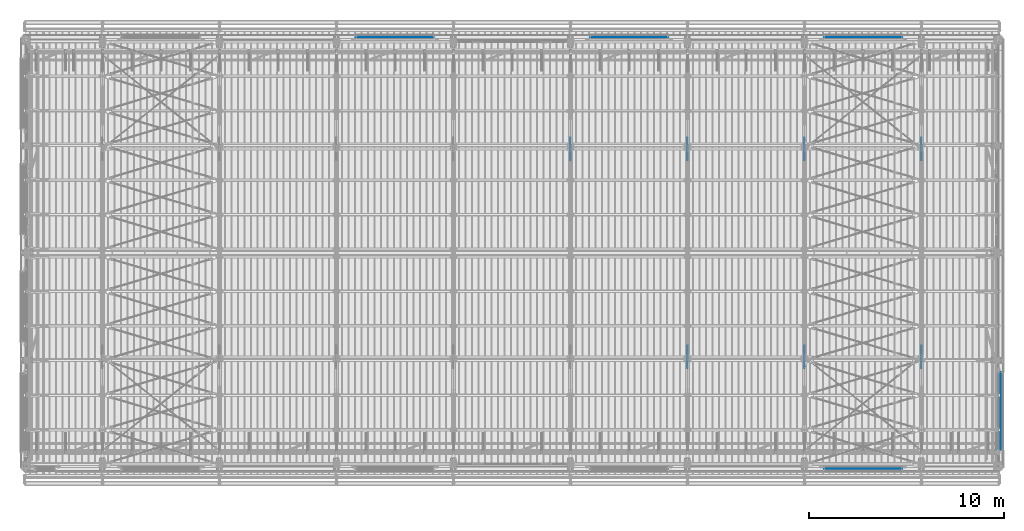
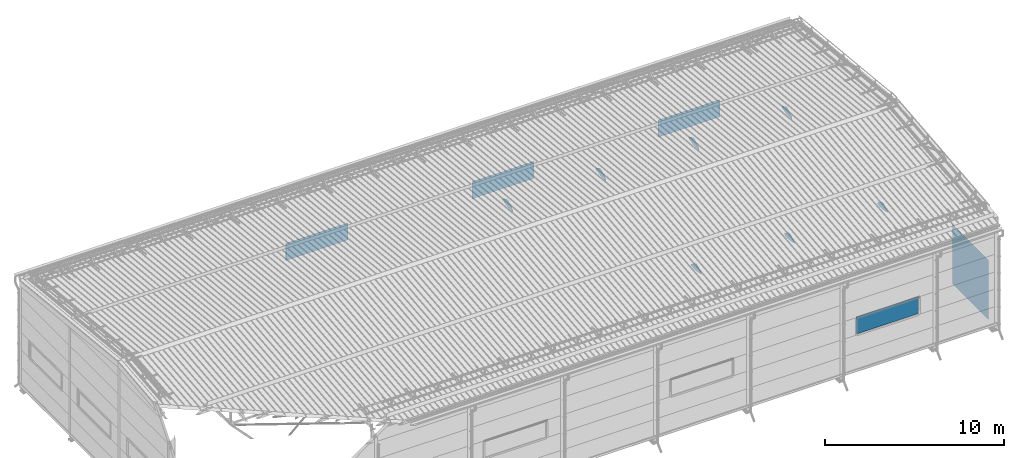
# One storey, part 106 of 709: 12 plates, 12 elements without a shape of their own.
"""IFC4 building model written with IfcOpenShell, lengths in millimetres."""

from ifc_helpers import new_model, si_unit, direction, frame, origin_with_axes, place, context, subcontext, project, spatial, line, indexed_curve, outline, extrude, material, element, aggregate, save


model = new_model("IFC4")

# Units and contexts
model_context = context("Model", 3, precision=0.2, world=origin_with_axes(), true_north=direction((0.0, 1.0)))
body_context = subcontext(model_context, "Body", "Model", "MODEL_VIEW")
ifc_project = project(units=[si_unit("LENGTHUNIT", "METRE", prefix="MILLI"), si_unit("AREAUNIT", "SQUARE_METRE"), si_unit("VOLUMEUNIT", "CUBIC_METRE"), si_unit("MASSUNIT", "GRAM", prefix="KILO"), si_unit("TIMEUNIT", "SECOND"), si_unit("PLANEANGLEUNIT", "RADIAN"), si_unit("SOLIDANGLEUNIT", "STERADIAN"), si_unit("THERMODYNAMICTEMPERATUREUNIT", "DEGREE_CELSIUS"), si_unit("LUMINOUSINTENSITYUNIT", "LUMEN")], contexts=[model_context])

# Site, building, storey
site_placement = place(None, origin_with_axes())
site = spatial("IfcSite", under=ifc_project, at=site_placement, CompositionType="ELEMENT")
building_placement = place(site_placement, origin_with_axes())
building = spatial("IfcBuilding", under=site, at=building_placement, Name="Undefined", CompositionType="ELEMENT")
storey_placement = place(building_placement, origin_with_axes())
storey = spatial("IfcBuildingStorey", under=building, at=storey_placement, Name="Undefined", CompositionType="ELEMENT", Elevation=0.0)

# Assembly, plate
assembly_1_placement = place(storey_placement, frame((28000.0, 16331.38656, 5980.00002), z_axis=(-1.0, 0.0, 0.0), x_axis=(0.0, -1.0, 0.0)))
assembly_1 = element("IfcElementAssembly", 1, at=assembly_1_placement, inside=storey)
ifc_material_1 = material(Name="C355-6", Category="STEEL")
plate_1_placement = place(assembly_1_placement, origin_with_axes())
plate_1 = element("IfcPlate", 2, at=plate_1_placement, material=ifc_material_1, ObjectType="448", context=body_context, shape_type="SolidModel", body=[
    extrude(outline(indexed_curve([(0.0, 0.0), (564.38656, 0.0), (564.38656, 130.0), (48.68656, 480.0), (-81.31344, 480.0), (-542.75823, 241.12615), (-568.25333, 113.65067)], segments=[line(1, 2, 3, 4, 5, 6, 7, 1)])), frame((0.0, 0.0, 4.0), z_axis=(0.0, 0.0, 1.0), x_axis=(1.0, 0.0, 0.0)), (0.0, 0.0, -1.0), 8.0),
])
aggregate(assembly_1, [plate_1])

assembly_2_placement = place(storey_placement, frame((34000.0, 5668.61344, 5980.00002), z_axis=(1.0, 0.0, 0.0), x_axis=(0.0, 1.0, 0.0)))
assembly_2 = element("IfcElementAssembly", 3, at=assembly_2_placement, inside=storey)
plate_2_placement = place(assembly_2_placement, origin_with_axes())
plate_2 = element("IfcPlate", 4, at=plate_2_placement, material=ifc_material_1, ObjectType="445", context=body_context, shape_type="SolidModel", body=[
    extrude(outline(indexed_curve([(0.0, 0.0), (564.38656, 0.0), (564.38656, 130.0), (45.08656, 480.0), (-84.91344, 480.0), (-542.75823, 241.12615), (-568.25333, 113.65067)], segments=[line(1, 2, 3, 4, 5, 6, 7, 1)])), frame((0.0, 0.0, 4.0), z_axis=(0.0, 0.0, 1.0), x_axis=(1.0, 0.0, 0.0)), (0.0, 0.0, -1.0), 8.0),
])
aggregate(assembly_2, [plate_2])

assembly_3_placement = place(storey_placement, frame((34000.0, 16331.38656, 5980.00002), z_axis=(-1.0, 0.0, 0.0), x_axis=(0.0, -1.0, 0.0)))
assembly_3 = element("IfcElementAssembly", 5, at=assembly_3_placement, inside=storey)
plate_3_placement = place(assembly_3_placement, origin_with_axes())
plate_3 = element("IfcPlate", 6, at=plate_3_placement, material=ifc_material_1, ObjectType="448", context=body_context, shape_type="SolidModel", body=[
    extrude(outline(indexed_curve([(0.0, 0.0), (564.38656, 0.0), (564.38656, 130.0), (48.68656, 480.0), (-81.31344, 480.0), (-542.75823, 241.12615), (-568.25333, 113.65067)], segments=[line(1, 2, 3, 4, 5, 6, 7, 1)])), frame((0.0, 0.0, 4.0), z_axis=(0.0, 0.0, 1.0), x_axis=(1.0, 0.0, 0.0)), (0.0, 0.0, -1.0), 8.0),
])
aggregate(assembly_3, [plate_3])

assembly_4_placement = place(storey_placement, frame((40000.0, 5668.61344, 5980.00002), z_axis=(1.0, 0.0, 0.0), x_axis=(0.0, 1.0, 0.0)))
assembly_4 = element("IfcElementAssembly", 7, at=assembly_4_placement, inside=storey)
plate_4_placement = place(assembly_4_placement, origin_with_axes())
plate_4 = element("IfcPlate", 8, at=plate_4_placement, material=ifc_material_1, ObjectType="445", context=body_context, shape_type="SolidModel", body=[
    extrude(outline(indexed_curve([(0.0, 0.0), (564.38656, 0.0), (564.38656, 130.0), (45.08656, 480.0), (-84.91344, 480.0), (-542.75823, 241.12615), (-568.25333, 113.65067)], segments=[line(1, 2, 3, 4, 5, 6, 7, 1)])), frame((0.0, 0.0, 4.0), z_axis=(0.0, 0.0, 1.0), x_axis=(1.0, 0.0, 0.0)), (0.0, 0.0, -1.0), 8.0),
])
aggregate(assembly_4, [plate_4])

assembly_5_placement = place(storey_placement, frame((40000.0, 16331.38656, 5980.00002), z_axis=(-1.0, 0.0, 0.0), x_axis=(0.0, -1.0, 0.0)))
assembly_5 = element("IfcElementAssembly", 9, at=assembly_5_placement, inside=storey)
plate_5_placement = place(assembly_5_placement, origin_with_axes())
plate_5 = element("IfcPlate", 10, at=plate_5_placement, material=ifc_material_1, ObjectType="448", context=body_context, shape_type="SolidModel", body=[
    extrude(outline(indexed_curve([(0.0, 0.0), (564.38656, 0.0), (564.38656, 130.0), (48.68656, 480.0), (-81.31344, 480.0), (-542.75823, 241.12615), (-568.25333, 113.65067)], segments=[line(1, 2, 3, 4, 5, 6, 7, 1)])), frame((0.0, 0.0, 4.0), z_axis=(0.0, 0.0, 1.0), x_axis=(1.0, 0.0, 0.0)), (0.0, 0.0, -1.0), 8.0),
])
aggregate(assembly_5, [plate_5])

assembly_6_placement = place(storey_placement, frame((46000.0, 5668.61344, 5980.00002), z_axis=(1.0, 0.0, 0.0), x_axis=(0.0, 1.0, 0.0)))
assembly_6 = element("IfcElementAssembly", 11, at=assembly_6_placement, inside=storey)
plate_6_placement = place(assembly_6_placement, origin_with_axes())
plate_6 = element("IfcPlate", 12, at=plate_6_placement, material=ifc_material_1, ObjectType="445", context=body_context, shape_type="SolidModel", body=[
    extrude(outline(indexed_curve([(0.0, 0.0), (564.38656, 0.0), (564.38656, 130.0), (45.08656, 480.0), (-84.91344, 480.0), (-542.75823, 241.12615), (-568.25333, 113.65067)], segments=[line(1, 2, 3, 4, 5, 6, 7, 1)])), frame((0.0, 0.0, 4.0), z_axis=(0.0, 0.0, 1.0), x_axis=(1.0, 0.0, 0.0)), (0.0, 0.0, -1.0), 8.0),
])
aggregate(assembly_6, [plate_6])

assembly_7_placement = place(storey_placement, frame((46000.0, 16331.38656, 5980.00002), z_axis=(-1.0, 0.0, 0.0), x_axis=(0.0, -1.0, 0.0)))
assembly_7 = element("IfcElementAssembly", 13, at=assembly_7_placement, inside=storey)
plate_7_placement = place(assembly_7_placement, origin_with_axes())
plate_7 = element("IfcPlate", 14, at=plate_7_placement, material=ifc_material_1, ObjectType="448", context=body_context, shape_type="SolidModel", body=[
    extrude(outline(indexed_curve([(0.0, 0.0), (564.38656, 0.0), (564.38656, 130.0), (48.68656, 480.0), (-81.31344, 480.0), (-542.75823, 241.12615), (-568.25333, 113.65067)], segments=[line(1, 2, 3, 4, 5, 6, 7, 1)])), frame((0.0, 0.0, 4.0), z_axis=(0.0, 0.0, 1.0), x_axis=(1.0, 0.0, 0.0)), (0.0, 0.0, -1.0), 8.0),
])
aggregate(assembly_7, [plate_7])

assembly_8_placement = place(storey_placement, frame((41000.0, -60.0, 2700.0), z_axis=(0.0, -1.0, 0.0), x_axis=(1.0, 0.0, 0.0)))
assembly_8 = element("IfcElementAssembly", 15, at=assembly_8_placement, inside=storey, Name="Opening")
ifc_material_2 = material()
plate_8_placement = place(assembly_8_placement, origin_with_axes())
plate_8 = element("IfcPlate", 16, at=plate_8_placement, material=ifc_material_2, Name="Opening", ObjectType="OP-10", context=body_context, shape_type="SolidModel", body=[
    extrude(outline(indexed_curve([(0.0, 0.0), (4000.0, 0.0), (4000.0, 1170.0), (0.0, 1170.0)], segments=[line(1, 2, 3, 4, 1)])), frame((0.0, 0.0, 5.0), z_axis=(0.0, 0.0, 1.0), x_axis=(1.0, 0.0, 0.0)), (0.0, 0.0, -1.0), 10.0),
])
aggregate(assembly_8, [plate_8])

assembly_9_placement = place(storey_placement, frame((17000.0, 22060.0, 2700.0), z_axis=(0.0, -1.0, 0.0), x_axis=(1.0, 0.0, 0.0)))
assembly_9 = element("IfcElementAssembly", 17, at=assembly_9_placement, inside=storey, Name="Opening")
plate_9_placement = place(assembly_9_placement, origin_with_axes())
plate_9 = element("IfcPlate", 18, at=plate_9_placement, material=ifc_material_2, Name="Opening", ObjectType="OP-10", context=body_context, shape_type="SolidModel", body=[
    extrude(outline(indexed_curve([(0.0, 0.0), (4000.0, 0.0), (4000.0, 1170.0), (0.0, 1170.0)], segments=[line(1, 2, 3, 4, 1)])), frame((0.0, 0.0, 5.0), z_axis=(0.0, 0.0, 1.0), x_axis=(1.0, 0.0, 0.0)), (0.0, 0.0, -1.0), 10.0),
])
aggregate(assembly_9, [plate_9])

assembly_10_placement = place(storey_placement, frame((29000.0, 22060.0, 2700.0), z_axis=(0.0, -1.0, 0.0), x_axis=(1.0, 0.0, 0.0)))
assembly_10 = element("IfcElementAssembly", 19, at=assembly_10_placement, inside=storey, Name="Opening")
plate_10_placement = place(assembly_10_placement, origin_with_axes())
plate_10 = element("IfcPlate", 20, at=plate_10_placement, material=ifc_material_2, Name="Opening", ObjectType="OP-10", context=body_context, shape_type="SolidModel", body=[
    extrude(outline(indexed_curve([(0.0, 0.0), (4000.0, 0.0), (4000.0, 1170.0), (0.0, 1170.0)], segments=[line(1, 2, 3, 4, 1)])), frame((0.0, 0.0, 5.0), z_axis=(0.0, 0.0, 1.0), x_axis=(1.0, 0.0, 0.0)), (0.0, 0.0, -1.0), 10.0),
])
aggregate(assembly_10, [plate_10])

assembly_11_placement = place(storey_placement, frame((41000.0, 22060.0, 2700.0), z_axis=(0.0, -1.0, 0.0), x_axis=(1.0, 0.0, 0.0)))
assembly_11 = element("IfcElementAssembly", 21, at=assembly_11_placement, inside=storey, Name="Opening")
plate_11_placement = place(assembly_11_placement, origin_with_axes())
plate_11 = element("IfcPlate", 22, at=plate_11_placement, material=ifc_material_2, Name="Opening", ObjectType="OP-10", context=body_context, shape_type="SolidModel", body=[
    extrude(outline(indexed_curve([(0.0, 0.0), (4000.0, 0.0), (4000.0, 1170.0), (0.0, 1170.0)], segments=[line(1, 2, 3, 4, 1)])), frame((0.0, 0.0, 5.0), z_axis=(0.0, 0.0, 1.0), x_axis=(1.0, 0.0, 0.0)), (0.0, 0.0, -1.0), 10.0),
])
aggregate(assembly_11, [plate_11])

assembly_12_placement = place(storey_placement, frame((50060.0, 880.0, -50.0), z_axis=(1.0, 0.0, 0.0), x_axis=(0.0, 1.0, 0.0)))
assembly_12 = element("IfcElementAssembly", 23, at=assembly_12_placement, inside=storey, Name="Opening")
plate_12_placement = place(assembly_12_placement, origin_with_axes())
plate_12 = element("IfcPlate", 24, at=plate_12_placement, material=ifc_material_2, Name="Opening", ObjectType="OP-11", context=body_context, shape_type="SolidModel", body=[
    extrude(outline(indexed_curve([(0.0, 0.0), (4000.0, 0.0), (4000.0, 4050.0), (0.0, 4050.0)], segments=[line(1, 2, 3, 4, 1)])), frame((0.0, 0.0, 5.0), z_axis=(0.0, 0.0, 1.0), x_axis=(1.0, 0.0, 0.0)), (0.0, 0.0, -1.0), 10.0),
])
aggregate(assembly_12, [plate_12])

save(model, "model.ifc")
